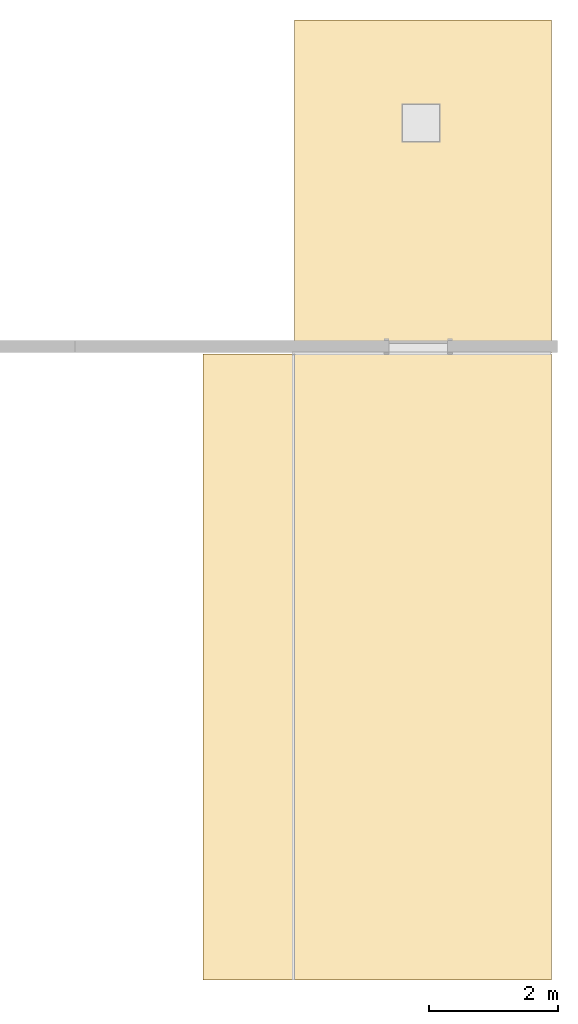
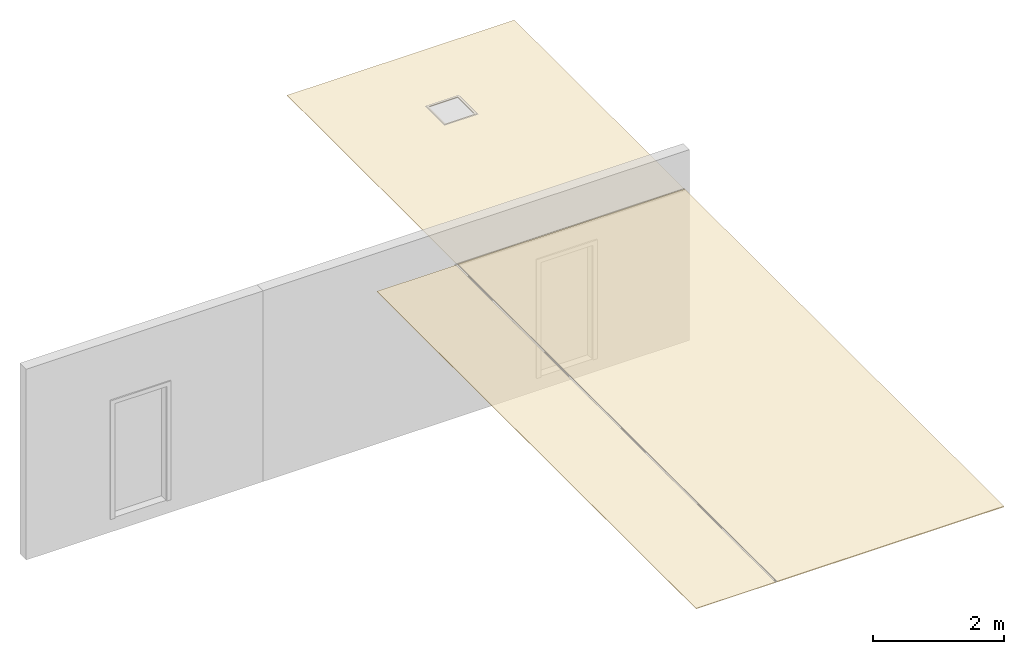
# One storey, part 2 of 4: 3 coverings.
"""IFC2X3 building model written with IfcOpenShell, lengths in millimetres."""

from ifc_helpers import new_model, entity, si_unit, converted_unit, derived_unit, direction, frame, frame_2d, origin, place, context, subcontext, project, spatial, polyline, rectangle, outline, extrude, material, layer, layer_set, layer_usage, type_object, element, save


model = new_model("IFC2X3")

# Units and contexts
model_context = context("Model", 3, precision=0.01, world=origin(), true_north=direction((6.12303176911189e-17, 1.0)))
body_context = subcontext(model_context, "Body", "Model", "MODEL_VIEW")
ifc_project = project(units=[si_unit("LENGTHUNIT", "METRE", prefix="MILLI"), si_unit("AREAUNIT", "SQUARE_METRE"), si_unit("VOLUMEUNIT", "CUBIC_METRE"), converted_unit("PLANEANGLEUNIT", "DEGREE", entity("IfcRatioMeasure", 0.0174532925199433), si_unit("PLANEANGLEUNIT", "RADIAN"), dimensions=[0, 0, 0, 0, 0, 0, 0]), si_unit("MASSUNIT", "GRAM", prefix="KILO"), derived_unit("MASSDENSITYUNIT", [(si_unit("MASSUNIT", "GRAM", prefix="KILO"), 1), (si_unit("LENGTHUNIT", "METRE"), -3)]), si_unit("TIMEUNIT", "SECOND"), si_unit("FREQUENCYUNIT", "HERTZ"), si_unit("THERMODYNAMICTEMPERATUREUNIT", "DEGREE_CELSIUS"), derived_unit("THERMALTRANSMITTANCEUNIT", [(si_unit("MASSUNIT", "GRAM", prefix="KILO"), 1), (si_unit("THERMODYNAMICTEMPERATUREUNIT", "KELVIN"), -1), (si_unit("TIMEUNIT", "SECOND"), -3)]), derived_unit("VOLUMETRICFLOWRATEUNIT", [(si_unit("LENGTHUNIT", "METRE"), 3), (si_unit("TIMEUNIT", "SECOND"), -1)]), si_unit("ELECTRICCURRENTUNIT", "AMPERE"), si_unit("ELECTRICVOLTAGEUNIT", "VOLT"), si_unit("POWERUNIT", "WATT"), si_unit("FORCEUNIT", "NEWTON", prefix="KILO"), si_unit("ILLUMINANCEUNIT", "LUX"), si_unit("LUMINOUSFLUXUNIT", "LUMEN"), si_unit("LUMINOUSINTENSITYUNIT", "CANDELA"), derived_unit("USERDEFINED", [(si_unit("MASSUNIT", "GRAM", prefix="KILO"), -1), (si_unit("LENGTHUNIT", "METRE"), -2), (si_unit("TIMEUNIT", "SECOND"), 3), (si_unit("LUMINOUSFLUXUNIT", "LUMEN"), 1)]), derived_unit("LINEARVELOCITYUNIT", [(si_unit("LENGTHUNIT", "METRE"), 1), (si_unit("TIMEUNIT", "SECOND"), -1)]), si_unit("PRESSUREUNIT", "PASCAL"), derived_unit("USERDEFINED", [(si_unit("LENGTHUNIT", "METRE"), -2), (si_unit("MASSUNIT", "GRAM", prefix="KILO"), 1), (si_unit("TIMEUNIT", "SECOND"), -2)])], contexts=[model_context])

# Site, building, storey
site_placement = place(None, origin())
site = spatial("IfcSite", under=ifc_project, at=site_placement, CompositionType="ELEMENT")
building_placement = place(site_placement, origin())
building = spatial("IfcBuilding", under=site, at=building_placement, CompositionType="ELEMENT")
storey_placement = place(building_placement, origin())
storey = spatial("IfcBuildingStorey", under=building, at=storey_placement, Name="Base Level", CompositionType="ELEMENT", Elevation=0.0)

# Coverings
ifc_material_1 = material(Name="Ceiling Tile - Smooth Tile with 600 x 600")
ifc_layer_1 = layer(ifc_material_1, 1.0)
ifc_layer_2 = layer(ifc_material_1, 15.0)
ifc_layer_set_1 = layer_set([ifc_layer_1, ifc_layer_2])
ifc_layer_usage_1 = layer_usage(ifc_layer_set_1, "AXIS3", "POSITIVE", 0.0)
covering_type_1 = type_object("IfcCoveringType", PredefinedType="CEILING")
covering_1_placement = place(building_placement, origin())
element("IfcCovering", 1, at=covering_1_placement, inside=storey, type_object=covering_type_1, material=ifc_layer_usage_1, PredefinedType="CEILING", context=body_context, shape_type="SweptSolid", body=[
    extrude(rectangle(XDim=9729.99999999997, YDim=3999.00000000004, at=frame_2d((-2082.85714285714, -284.357142857139), x_axis=(1.0, 0.0))), frame((204682.877410076, 39409.7765232506, 2600.0), z_axis=(0.0, 0.0, 1.0), x_axis=(0.0, 1.0, 0.0)), (0.0, 0.0, 1.0), 16.0000000000002),
])
ifc_material_2 = material(Name="ceiling Flush Plastered - 12mm")
ifc_layer_3 = layer(ifc_material_2, 9.0)
ifc_layer_set_2 = layer_set([ifc_layer_3])
ifc_layer_usage_2 = layer_usage(ifc_layer_set_2, "AXIS3", "POSITIVE", 0.0)
covering_type_2 = type_object("IfcCoveringType", PredefinedType="CEILING")
covering_2_placement = place(building_placement, origin())
element("IfcCovering", 2, at=covering_2_placement, inside=storey, type_object=covering_type_2, material=ifc_layer_usage_2, PredefinedType="CEILING", context=body_context, shape_type="SweptSolid", body=[
    extrude(outline(polyline([(-2589.50000000001, -1999.5), (2589.50000000001, -1999.5), (2589.50000000002, 1999.5), (-2589.5, 1999.50000000004), (-2589.50000000001, -1999.5)]), holes=[polyline([(1243.17042473065, 284.613281379595), (1243.17042473064, -226.086718620419), (732.470424730654, -226.086718620429), (732.470424730661, 284.613281379585), (1243.17042473065, 284.613281379595)])]), frame((204967.234552934, 44798.4193803935, 2602.0), z_axis=(0.0, 0.0, 1.0), x_axis=(0.0, 1.0, 0.0)), (0.0, 0.0, 1.0), 9.00000000000012),
])
ifc_layer_4 = layer(ifc_material_2, 11.0)
ifc_layer_set_3 = layer_set([ifc_layer_4])
ifc_layer_usage_3 = layer_usage(ifc_layer_set_3, "AXIS3", "POSITIVE", 0.0)
covering_type_3 = type_object("IfcCoveringType", PredefinedType="CEILING")
covering_3_placement = place(building_placement, origin())
element("IfcCovering", 3, at=covering_3_placement, inside=storey, type_object=covering_type_3, material=ifc_layer_usage_3, PredefinedType="CEILING", context=body_context, shape_type="SweptSolid", body=[
    extrude(rectangle(XDim=9729.99999999997, YDim=1402.99999999998, at=frame_2d((2.27373675443232e-12, 1.73372427525464e-11), x_axis=(1.0, 0.0))), frame((202249.234552934, 37326.9193803935, 2600.0), z_axis=(0.0, 0.0, 1.0), x_axis=(0.0, -1.0, 0.0)), (0.0, 0.0, 1.0), 11.0000000000002),
])

save(model, "model.ifc")
